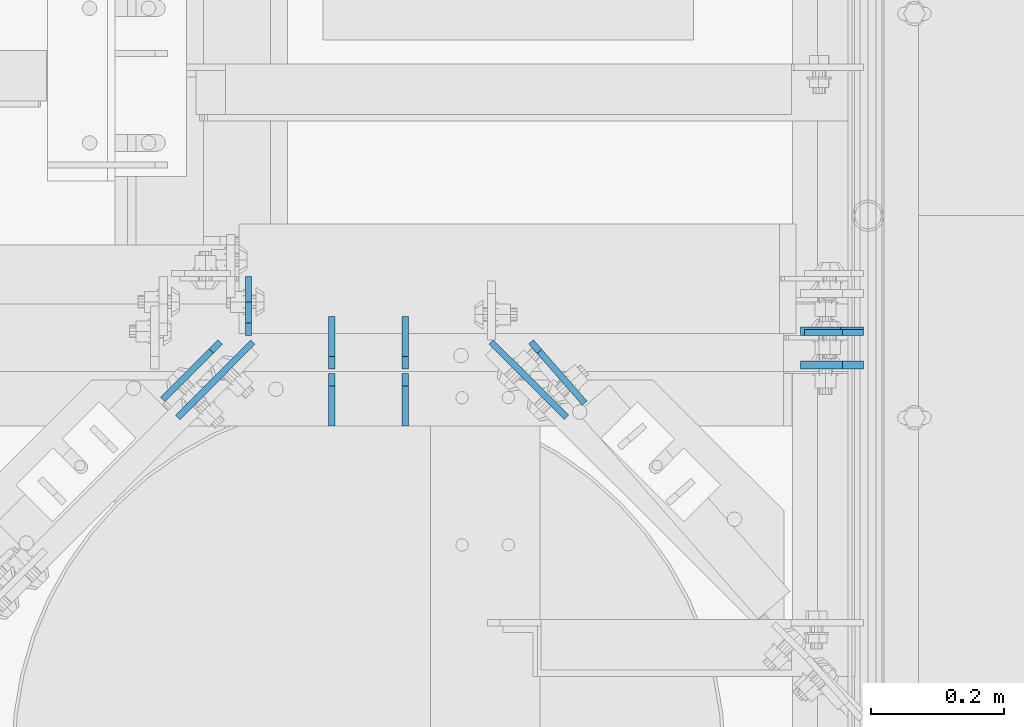
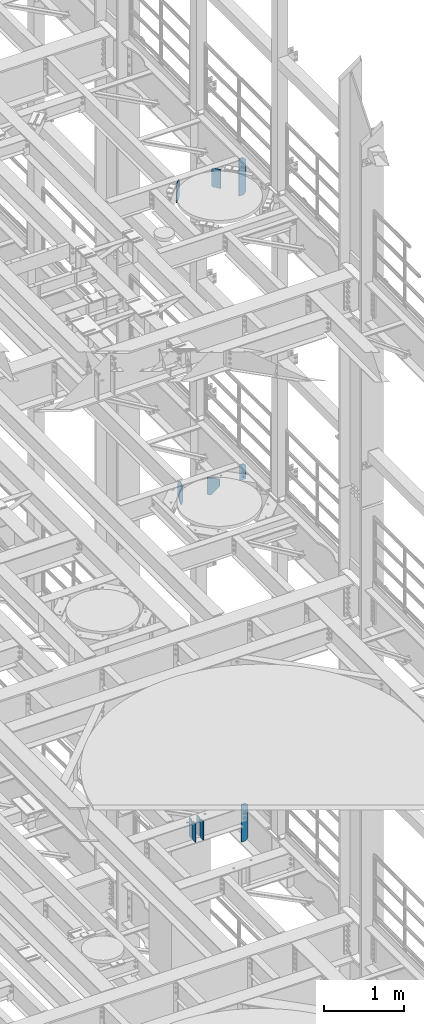
# One storey, part 1665 of 1876: 12 plates, 6 elements without a shape of their own.
"""IFC2X3 building model written with IfcOpenShell, lengths in millimetres."""

from ifc_helpers import new_model, si_unit, frame, origin_with_axes, place, context, subcontext, project, spatial, faceted_brep, material, type_object, element, aggregate, save


model = new_model("IFC2X3")

# Units and contexts
model_context = context("Model", 3, precision=1e-05, world=origin_with_axes())
body_context = subcontext(model_context, "Body", "Model", "MODEL_VIEW")
ifc_project = project(units=[si_unit("LENGTHUNIT", "METRE", prefix="MILLI"), si_unit("AREAUNIT", "SQUARE_METRE"), si_unit("VOLUMEUNIT", "CUBIC_METRE"), si_unit("MASSUNIT", "GRAM", prefix="KILO"), si_unit("TIMEUNIT", "SECOND"), si_unit("PLANEANGLEUNIT", "RADIAN"), si_unit("SOLIDANGLEUNIT", "STERADIAN"), si_unit("THERMODYNAMICTEMPERATUREUNIT", "DEGREE_CELSIUS"), si_unit("LUMINOUSINTENSITYUNIT", "LUMEN")], contexts=[model_context])

# Site, building, storey
site_placement = place(None, origin_with_axes())
site = spatial("IfcSite", under=ifc_project, at=site_placement, CompositionType="ELEMENT")
building_placement = place(site_placement, origin_with_axes())
building = spatial("IfcBuilding", under=site, at=building_placement, Name="Undefined", CompositionType="ELEMENT")
storey_placement = place(building_placement, origin_with_axes())
storey = spatial("IfcBuildingStorey", under=building, at=storey_placement, Name="Undefined", CompositionType="ELEMENT", Elevation=0.0)

# Assembly, plate
assembly_1_placement = place(storey_placement, origin_with_axes())
assembly_1 = element("IfcElementAssembly", 1, at=assembly_1_placement, inside=storey, Name="BEAM", AssemblyPlace="NOTDEFINED", PredefinedType="RIGID_FRAME")
ifc_material = material(Name="STEEL/A36")
plate_type_1 = type_object("IfcPlateType", PredefinedType="NOTDEFINED")
plate_1_placement = place(assembly_1_placement, frame((7612.85625, 4395.78799991608, 13042.9), z_axis=(0.0, 0.0, 1.0), x_axis=(-1.0, 0.0, 0.0)))
plate_1 = element("IfcPlate", 2, at=plate_1_placement, type_object=plate_type_1, material=ifc_material, Name="PLATE", context=body_context, shape_type="Brep", body=[
    faceted_brep([(0.0, -4.76249999999982, 0.0), (0.0, -4.76249999999982, 209.550003051758), (0.0, 4.76249999999982, 209.550003051758), (0.0, 4.76249999999982, 0.0), (31.75, -4.76249999999982, 241.300003051758), (31.75, 4.76249999999982, 241.300003051758), (88.9000015258788, -4.76249999999982, 241.300003051758), (88.9000015258788, 4.76249999999982, 241.300003051758), (88.9000015258789, -4.76249999999982, 0.0), (88.9000015258789, 4.76249999999982, 0.0)], [[[0, 1, 2, 3]], [[1, 4, 5, 2]], [[4, 6, 7, 5]], [[6, 8, 9, 7]], [[8, 0, 3, 9]], [[5, 7, 9, 3, 2]], [[8, 6, 4, 1, 0]]]),
])
aggregate(assembly_1, [plate_1])

assembly_2_placement = place(storey_placement, origin_with_axes())
assembly_2 = element("IfcElementAssembly", 3, at=assembly_2_placement, inside=storey, Name="BEAM", AssemblyPlace="NOTDEFINED", PredefinedType="RIGID_FRAME")
plate_2_placement = place(assembly_2_placement, frame((6684.96200008392, 4391.025, 13012.7375), z_axis=(0.0, 0.0, 1.0), x_axis=(0.0, 1.0, 0.0)))
plate_2 = element("IfcPlate", 4, at=plate_2_placement, type_object=plate_type_1, material=ifc_material, Name="PLATE", context=body_context, shape_type="Brep", body=[
    faceted_brep([(0.0, -4.76249999999982, 19.0499992370605), (0.0, -4.76249999999982, 271.462512969971), (0.0, 4.76249999999982, 271.462512969971), (0.0, 4.76249999999982, 19.0499992370605), (19.0499992370605, -4.76249999999982, 290.512512207031), (19.0499992370605, 4.76249999999982, 290.512512207031), (50.8000030517578, -4.76249999999982, 290.512512207031), (50.8000030517578, 4.76249999999982, 290.512512207031), (88.9000015258789, -4.76249999999982, 252.41251373291), (88.9000015258789, 4.76249999999982, 252.41251373291), (88.9000015258789, -4.76249999999982, 38.0999984741211), (88.9000015258789, 4.76249999999982, 38.0999984741211), (50.8000030517578, -4.76249999999982, 0.0), (50.8000030517578, 4.76249999999982, 0.0), (19.0499992370605, -4.76249999999982, 0.0), (19.0499992370605, 4.76249999999982, 0.0)], [[[0, 1, 2, 3]], [[1, 4, 5, 2]], [[4, 6, 7, 5]], [[6, 8, 9, 7]], [[8, 10, 11, 9]], [[10, 12, 13, 11]], [[12, 14, 15, 13]], [[14, 0, 3, 15]], [[5, 7, 9, 11, 13, 15, 3, 2]], [[14, 12, 10, 8, 6, 4, 1, 0]]]),
])

assembly_3_placement = place(storey_placement, origin_with_axes())
assembly_3 = element("IfcElementAssembly", 5, at=assembly_3_placement, inside=storey, Name="BEAM", AssemblyPlace="NOTDEFINED", PredefinedType="RIGID_FRAME")
plate_type_2 = type_object("IfcPlateType", PredefinedType="NOTDEFINED")
plate_3_placement = place(assembly_3_placement, frame((7612.85625, 4397.37500009537, 17387.8875), z_axis=(0.0, 0.0, 1.0), x_axis=(-1.0, 0.0, 0.0)))
plate_3 = element("IfcPlate", 6, at=plate_3_placement, type_object=plate_type_2, material=ifc_material, Name="PLATE", context=body_context, shape_type="Brep", body=[
    faceted_brep([(0.0, -6.34999999999991, 34.9249992370605), (0.0, -6.34999999999991, 534.987476348877), (0.0, 6.34999999999991, 534.987476348877), (0.0, 6.34999999999991, 34.9249992370605), (34.9249992370605, -6.34999999999991, 569.912475585938), (34.9249992370605, 6.34999999999991, 569.912475585938), (95.25, -6.35000000000036, 569.912475585938), (95.25, 6.35000000000036, 569.912475585938), (95.25, -6.35000000000036, 0.0), (95.25, 6.35000000000036, 0.0), (34.9249992370605, -6.34999999999991, 0.0), (34.9249992370605, 6.34999999999991, 0.0)], [[[0, 1, 2, 3]], [[1, 4, 5, 2]], [[4, 6, 7, 5]], [[6, 8, 9, 7]], [[8, 10, 11, 9]], [[10, 0, 3, 11]], [[5, 7, 9, 11, 3, 2]], [[10, 8, 6, 4, 1, 0]]]),
])
aggregate(assembly_3, [plate_3])

assembly_4_placement = place(storey_placement, origin_with_axes())
assembly_4 = element("IfcElementAssembly", 7, at=assembly_4_placement, inside=storey, Name="BEAM", AssemblyPlace="NOTDEFINED", PredefinedType="RIGID_FRAME")
plate_4_placement = place(assembly_4_placement, frame((7612.85625, 4346.57500009537, 7558.0875), z_axis=(0.0, 0.0, 1.0), x_axis=(-1.0, 0.0, 0.0)))
plate_4 = element("IfcPlate", 8, at=plate_4_placement, type_object=plate_type_2, material=ifc_material, Name="PLATE", context=body_context, shape_type="Brep", body=[
    faceted_brep([(0.0, -6.34999999999991, 31.75), (0.0, -6.35000000000036, 538.162475585938), (0.0, 6.35000000000036, 538.162475585938), (0.0, 6.34999999999991, 31.75), (31.75, -6.35000000000036, 569.912475585938), (31.75, 6.35000000000036, 569.912475585938), (95.25, -6.35000000000036, 569.912475585938), (95.25, 6.35000000000036, 569.912475585938), (95.25, -6.35000000000036, 0.0), (95.25, 6.35000000000036, 0.0), (31.75, -6.34999999999991, 0.0), (31.75, 6.34999999999991, 0.0)], [[[0, 1, 2, 3]], [[1, 4, 5, 2]], [[4, 6, 7, 5]], [[6, 8, 9, 7]], [[8, 10, 11, 9]], [[10, 0, 3, 11]], [[5, 7, 9, 11, 3, 2]], [[10, 8, 6, 4, 1, 0]]]),
])
aggregate(assembly_4, [plate_4])

# Assembly, plates
assembly_5_placement = place(storey_placement, origin_with_axes())
assembly_5 = element("IfcElementAssembly", 9, at=assembly_5_placement, inside=storey, Name="BEAM", AssemblyPlace="NOTDEFINED", PredefinedType="RIGID_FRAME")
plate_type_3 = type_object("IfcPlateType", PredefinedType="NOTDEFINED")
plate_5_placement = place(assembly_5_placement, frame((6921.4995, 4254.5, 7850.1875), z_axis=(0.0, 0.0, 1.0), x_axis=(0.0, 1.0, 0.0)))
plate_5 = element("IfcPlate", 10, at=plate_5_placement, type_object=plate_type_3, material=ifc_material, Name="PLATE", context=body_context, shape_type="Brep", body=[
    faceted_brep([(0.0, -4.76249999999982, 0.0), (0.0, -4.76249999999982, 292.100006103516), (0.0, 4.76249999999982, 292.100006103516), (0.0, 4.76249999999982, 0.0), (60.3250007629395, -4.76249999999982, 292.100006103516), (60.3250007629395, 4.76249999999982, 292.100006103516), (79.375, -4.76249999999982, 273.050006866455), (79.375, 4.76249999999982, 273.050006866455), (79.375, -4.76249999999982, 19.0499992370605), (79.375, 4.76249999999982, 19.0499992370605), (60.3250007629395, -4.76249999999982, 0.0), (60.3250007629395, 4.76249999999982, 0.0)], [[[0, 1, 2, 3]], [[1, 4, 5, 2]], [[4, 6, 7, 5]], [[6, 8, 9, 7]], [[8, 10, 11, 9]], [[10, 0, 3, 11]], [[5, 7, 9, 11, 3, 2]], [[10, 8, 6, 4, 1, 0]]]),
])
plate_6_placement = place(assembly_5_placement, frame((6921.4995, 4340.225, 7850.1875), z_axis=(0.0, 0.0, 1.0), x_axis=(0.0, 1.0, 0.0)))
plate_6 = element("IfcPlate", 11, at=plate_6_placement, type_object=plate_type_3, material=ifc_material, Name="PLATE", context=body_context, shape_type="Brep", body=[
    faceted_brep([(0.0, -4.76249999999982, 19.0499992370605), (0.0, -4.76249999999982, 273.050006866455), (0.0, 4.76249999999982, 273.050006866455), (0.0, 4.76249999999982, 19.0499992370605), (19.0499992370605, -4.76249999999982, 292.100006103516), (19.0499992370605, 4.76249999999982, 292.100006103516), (79.375, -4.76249999999982, 292.100006103516), (79.375, 4.76249999999982, 292.100006103516), (79.375, -4.76250000000073, 0.0), (79.375, 4.76250000000073, 0.0), (19.0499992370605, -4.76249999999982, 0.0), (19.0499992370605, 4.76249999999982, 0.0)], [[[0, 1, 2, 3]], [[1, 4, 5, 2]], [[4, 6, 7, 5]], [[6, 8, 9, 7]], [[8, 10, 11, 9]], [[10, 0, 3, 11]], [[5, 7, 9, 11, 3, 2]], [[10, 8, 6, 4, 1, 0]]]),
])
plate_7_placement = place(assembly_5_placement, frame((6810.375, 4254.5, 7850.1875), z_axis=(0.0, 0.0, 1.0), x_axis=(0.0, 1.0, 0.0)))
plate_7 = element("IfcPlate", 12, at=plate_7_placement, type_object=plate_type_3, material=ifc_material, Name="PLATE", context=body_context, shape_type="Brep", body=[
    faceted_brep([(0.0, -4.76249999999982, 0.0), (0.0, -4.76249999999982, 292.100006103516), (0.0, 4.76249999999982, 292.100006103516), (0.0, 4.76249999999982, 0.0), (60.3250007629395, -4.76249999999982, 292.100006103516), (60.3250007629395, 4.76249999999982, 292.100006103516), (79.375, -4.76249999999982, 273.050006866455), (79.375, 4.76249999999982, 273.050006866455), (79.375, -4.76249999999982, 19.0499992370605), (79.375, 4.76249999999982, 19.0499992370605), (60.3250007629395, -4.76249999999982, 0.0), (60.3250007629395, 4.76249999999982, 0.0)], [[[0, 1, 2, 3]], [[1, 4, 5, 2]], [[4, 6, 7, 5]], [[6, 8, 9, 7]], [[8, 10, 11, 9]], [[10, 0, 3, 11]], [[5, 7, 9, 11, 3, 2]], [[10, 8, 6, 4, 1, 0]]]),
])
plate_8_placement = place(assembly_5_placement, frame((6810.375, 4340.225, 7850.1875), z_axis=(0.0, 0.0, 1.0), x_axis=(0.0, 1.0, 0.0)))
plate_8 = element("IfcPlate", 13, at=plate_8_placement, type_object=plate_type_3, material=ifc_material, Name="PLATE", context=body_context, shape_type="Brep", body=[
    faceted_brep([(0.0, -4.76249999999982, 19.0499992370605), (0.0, -4.76249999999982, 273.050006866455), (0.0, 4.76249999999982, 273.050006866455), (0.0, 4.76249999999982, 19.0499992370605), (19.0499992370605, -4.76249999999982, 292.100006103516), (19.0499992370605, 4.76249999999982, 292.100006103516), (79.375, -4.76249999999982, 292.100006103516), (79.375, 4.76249999999982, 292.100006103516), (79.375, -4.76250000000073, 0.0), (79.375, 4.76250000000073, 0.0), (19.0499992370605, -4.76249999999982, 0.0), (19.0499992370605, 4.76249999999982, 0.0)], [[[0, 1, 2, 3]], [[1, 4, 5, 2]], [[4, 6, 7, 5]], [[6, 8, 9, 7]], [[8, 10, 11, 9]], [[10, 0, 3, 11]], [[5, 7, 9, 11, 3, 2]], [[10, 8, 6, 4, 1, 0]]]),
])
aggregate(assembly_5, [plate_5, plate_6, plate_7, plate_8])

assembly_6_placement = place(storey_placement, origin_with_axes())
assembly_6 = element("IfcElementAssembly", 14, at=assembly_6_placement, inside=storey, Name="BEAM", AssemblyPlace="NOTDEFINED", PredefinedType="RIGID_FRAME")
plate_type_4 = type_object("IfcPlateType", PredefinedType="NOTDEFINED")
plate_9_placement = place(assembly_6_placement, frame((7111.32442699274, 4381.53887230785, 17975.2625), z_axis=(0.658504607797722, -0.752576694768825, 0.0), x_axis=(0.0, 0.0, -1.0)))
plate_9 = element("IfcPlate", 15, at=plate_9_placement, type_object=plate_type_4, material=ifc_material, Name="PLATE", context=body_context, shape_type="Brep", body=[
    faceted_brep([(0.0, -4.76249999999982, 19.0499992370605), (0.0, -4.762500000008, 122.840980529847), (0.0, 4.76249999999709, 122.840980529847), (0.0, 4.76249999999982, 19.0499992370605), (290.512481689453, -4.762500000008, 122.840980529847), (290.512481689453, 4.76249999999709, 122.840980529847), (290.512481689453, -4.76250000000255, 19.0499992370701), (290.512481689453, 4.76250000000073, 19.0499992370701), (271.462482452393, -4.76250000000255, -9.09494701772928e-13), (271.462482452393, 4.76250000000255, -4.54747350886464e-13), (19.0499992370605, -4.76249999999982, 0.0), (19.0499992370605, 4.76249999999982, 0.0)], [[[0, 1, 2, 3]], [[1, 4, 5, 2]], [[4, 6, 7, 5]], [[6, 8, 9, 7]], [[8, 10, 11, 9]], [[10, 0, 3, 11]], [[5, 7, 9, 11, 3, 2]], [[10, 8, 6, 4, 1, 0]]]),
])
plate_10_placement = place(assembly_6_placement, frame((6642.36683842951, 4381.3103386185, 17975.2625), z_axis=(-0.706490692026477, -0.707722334026523, 0.0), x_axis=(0.0, 0.0, -1.0)))
plate_10 = element("IfcPlate", 16, at=plate_10_placement, type_object=plate_type_4, material=ifc_material, Name="PLATE", context=body_context, shape_type="Brep", body=[
    faceted_brep([(0.0, -4.76249999999982, 19.0499992370605), (0.0, -4.76250000000073, 122.73646545413), (0.0, 4.76250000000164, 122.736465454129), (0.0, 4.76249999999982, 19.0499992370605), (290.512481689453, -4.76250000000073, 122.73646545413), (290.512481689453, 4.76250000000164, 122.736465454129), (290.512481689453, -4.76250000000255, 19.0499992370701), (290.512481689453, 4.76250000000073, 19.0499992370701), (271.462482452393, -4.76250000000255, -9.09494701772928e-13), (271.462482452393, 4.76250000000255, -4.54747350886464e-13), (19.0499992370605, -4.76249999999982, 0.0), (19.0499992370605, 4.76249999999982, 0.0)], [[[0, 1, 2, 3]], [[1, 4, 5, 2]], [[4, 6, 7, 5]], [[6, 8, 9, 7]], [[8, 10, 11, 9]], [[10, 0, 3, 11]], [[5, 7, 9, 11, 3, 2]], [[10, 8, 6, 4, 1, 0]]]),
])
aggregate(assembly_6, [plate_9, plate_10])

# Plate
plate_type_5 = type_object("IfcPlateType", PredefinedType="NOTDEFINED")
plate_11_placement = place(assembly_2_placement, frame((7050.88812945471, 4381.30279942609, 13271.5), z_axis=(0.708073497960694, -0.706138740960802, 0.0), x_axis=(0.0, 0.0, -1.0)))
plate_11 = element("IfcPlate", 17, at=plate_11_placement, type_object=plate_type_5, material=ifc_material, Name="PLATE", context=body_context, shape_type="Brep", body=[
    faceted_brep([(0.0, -4.76249999999982, 0.0), (0.0, -4.76250000003256, 160.834030151437), (0.0, 4.76249999997071, 160.834030151439), (0.0, 4.76249999999982, 0.0), (265.112487792969, -4.76250000000164, -1.13686837721616e-12), (265.112487792969, 4.76250000000346, 1.13686837721616e-12), (265.112487792969, -4.76250000001073, 50.799999448456), (114.299999089737, -4.76250000003256, 160.834030151437), (114.299999089733, 4.76249999997071, 160.834030151439), (265.112487792969, 4.76249999999254, 50.7999994484537)], [[[0, 1, 2, 3]], [[4, 0, 3, 5]], [[1, 0, 4, 6, 7]], [[2, 1, 7, 8]], [[5, 3, 2, 8, 9]], [[4, 5, 9, 6]], [[8, 7, 6, 9]]]),
])

plate_12_placement = place(assembly_2_placement, frame((6691.71528920621, 4381.31033754046, 13271.5), z_axis=(-0.706490692026477, -0.707722334026523, 0.0), x_axis=(0.0, 0.0, -1.0)))
plate_12 = element("IfcPlate", 18, at=plate_12_placement, type_object=plate_type_5, material=ifc_material, Name="PLATE", context=body_context, shape_type="Brep", body=[
    faceted_brep([(0.0, -4.76249999999982, 0.0), (0.0, -4.76250000003438, 160.836471557663), (0.0, 4.76249999996844, 160.836471557664), (0.0, 4.76249999999982, 0.0), (241.300006866455, -4.76250000000073, -9.09494701772928e-13), (241.300006866455, 4.76250000000073, 4.54747350886464e-13), (260.350006103516, -4.76250000000073, 19.0499992370633), (260.350006103516, 4.76250000000073, 19.0499992370633), (260.350006103516, -4.76250000001392, 59.2364683765936), (114.299635995336, -4.76250000003438, 160.836471557663), (114.299635995334, 4.76249999996844, 160.836471557664), (260.350006103516, 4.76249999998845, 59.2364683765936)], [[[0, 1, 2, 3]], [[4, 0, 3, 5]], [[6, 4, 5, 7]], [[1, 0, 4, 6, 8, 9]], [[2, 1, 9, 10]], [[7, 5, 3, 2, 10, 11]], [[6, 7, 11, 8]], [[10, 9, 8, 11]]]),
])

aggregate(assembly_2, [plate_11, plate_12, plate_2])

save(model, "model.ifc")
